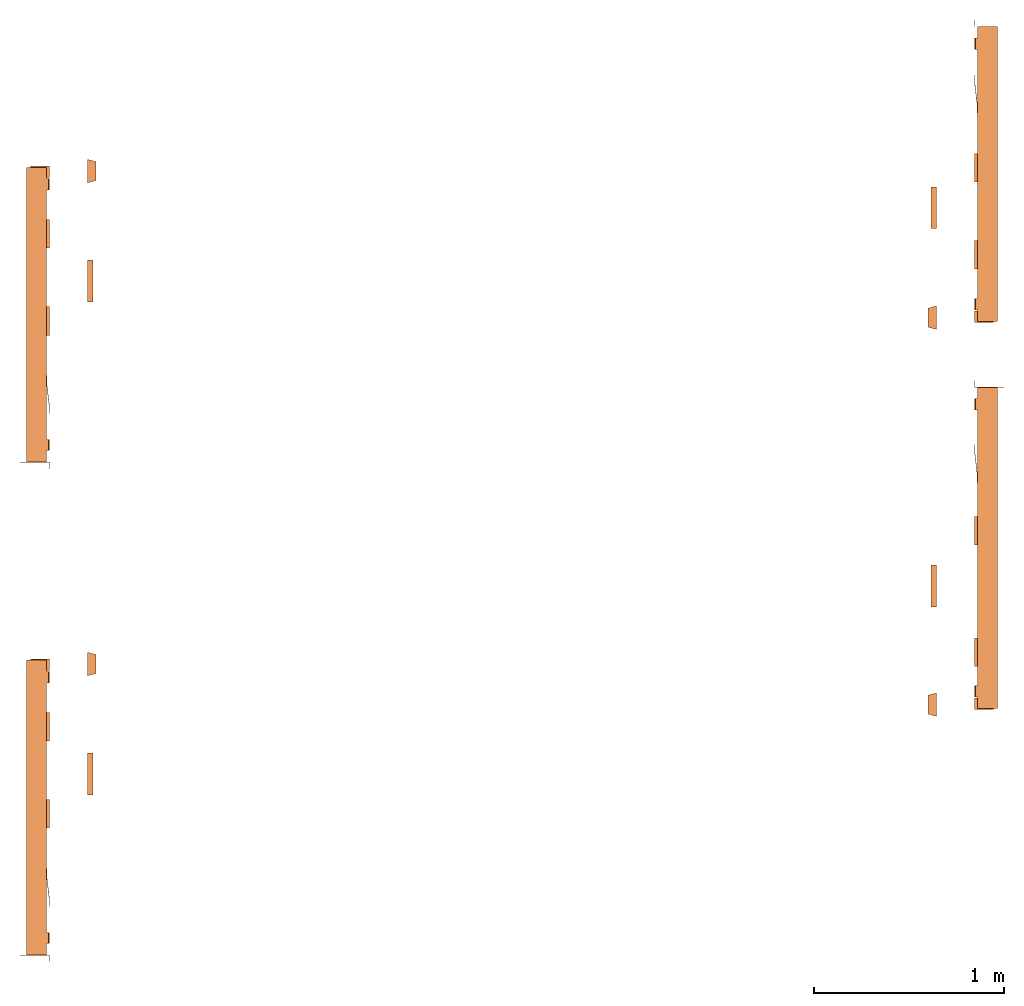
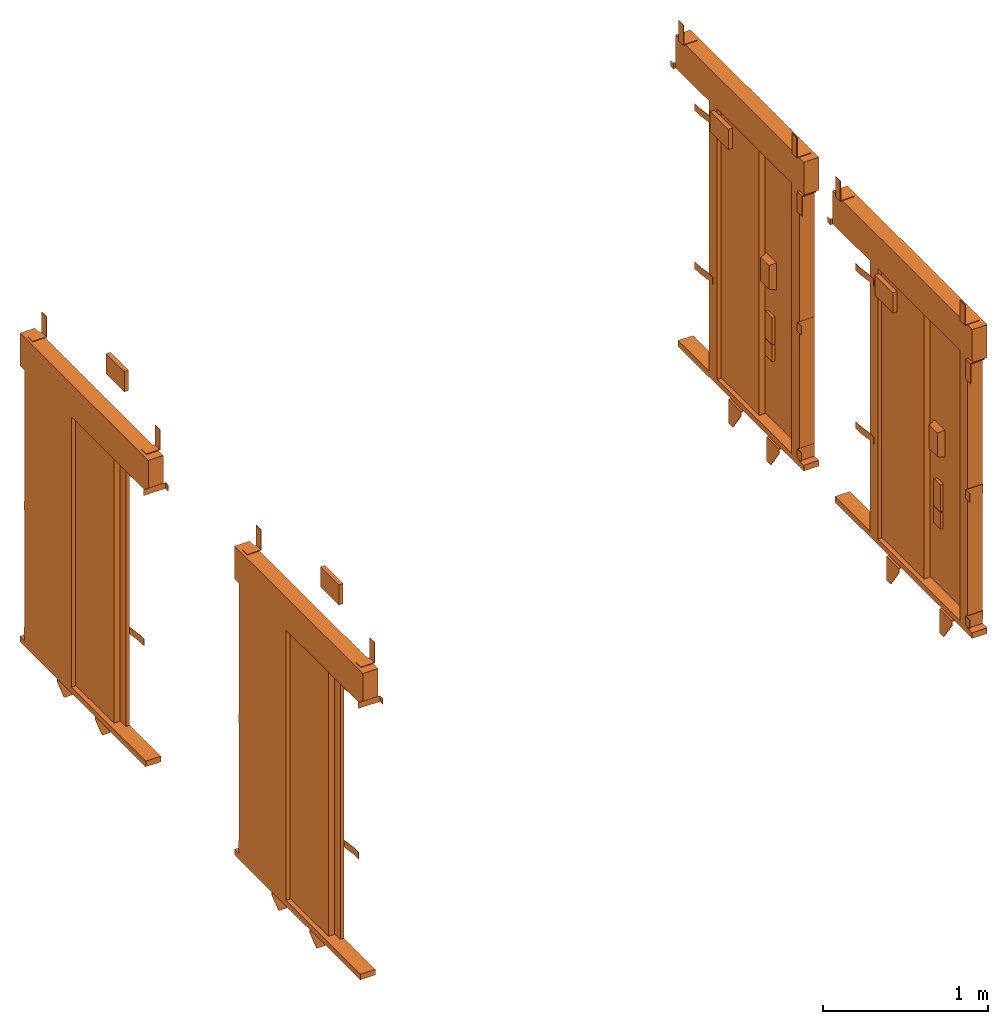
# One storey: 4 proxies.
"""IFC2X3 building model written with IfcOpenShell, lengths in millimetres."""

import ifcopenshell
import ifcopenshell.guid

model = None  # the IFC model being written
_history = None  # IfcOwnerHistory: only IFC2X3 demands one
_inside = {}  # id of a spatial element -> (the spatial element, [elements in it])
_under = {}  # id of a project, library or spatial element -> (it, [spatial elements below it])
_declared = {}  # id of a project -> (the project, [libraries it declares])
_typed = {}  # id of a type object -> (the type object, [elements of that type])
_made_of = {}  # id of a material, layer set ... -> (it, [elements and type objects made of it])


def new_model(schema):
    """Start an empty IFC model of exactly this schema.

    Asked for "IFC4X3", IfcOpenShell would pick the latest addendum, in which some entities
    have other attributes; the version numbers below select the first issue.
    IFC2X3 requires an IfcOwnerHistory on every rooted entity: one is made here for all.
    """
    global model, _history
    if schema == "IFC4X3":
        model = ifcopenshell.file(schema_version=(4, 3, 0, 0))
    else:
        model = ifcopenshell.file(schema=schema)
    _inside.clear()
    _under.clear()
    _declared.clear()
    _typed.clear()
    _made_of.clear()
    _history = None
    if model.schema == "IFC2X3":
        org = make("IfcOrganization", Name="unknown")
        user = make(
            "IfcPersonAndOrganization",
            ThePerson=make("IfcPerson", FamilyName="unknown"),
            TheOrganization=org,
        )
        app = make(
            "IfcApplication",
            ApplicationDeveloper=org,
            Version="unknown",
            ApplicationFullName="unknown",
            ApplicationIdentifier="unknown",
        )
        _history = make(
            "IfcOwnerHistory",
            OwningUser=user,
            OwningApplication=app,
            ChangeAction="ADDED",
            CreationDate=0,
        )
    return model


def make(cls, **values):
    """One entity of the class cls with the attributes given. An attribute that is None is left unset."""
    return model.create_entity(
        cls, **{name: value for name, value in values.items() if value is not None}
    )


def entity(cls, *values):
    """Any entity or typed value of the class cls, its attributes in the order of the schema. None: left unset."""
    e = model.create_entity(cls)
    for i, value in enumerate(values):
        if value is not None:
            e[i] = value
    return e


def rooted(cls, **values):
    """An entity with a GlobalId (a new one), such as an element, a storey or a relation."""
    return make(cls, GlobalId=ifcopenshell.guid.new(), OwnerHistory=_history, **values)


def si_unit(unit_type, name, prefix=None):
    """IfcSIUnit, for example si_unit("LENGTHUNIT", "METRE", prefix="MILLI")."""
    return make("IfcSIUnit", UnitType=unit_type, Prefix=prefix, Name=name)


def converted_unit(unit_type, name, factor, base, dimensions=None, offset=None):
    """IfcConversionBasedUnit, such as the inch: factor (a typed value) times the base unit."""
    return make(
        "IfcConversionBasedUnit"
        if offset is None
        else "IfcConversionBasedUnitWithOffset",
        ConversionOffset=offset,
        Dimensions=None
        if dimensions is None
        else entity("IfcDimensionalExponents", *dimensions),
        UnitType=unit_type,
        Name=name,
        ConversionFactor=make(
            "IfcMeasureWithUnit", ValueComponent=factor, UnitComponent=base
        ),
    )


def derived_unit(unit_type, elements):
    """IfcDerivedUnit: a product of units, each with its exponent."""
    return make(
        "IfcDerivedUnit",
        Elements=[
            make("IfcDerivedUnitElement", Unit=unit, Exponent=power)
            for unit, power in elements
        ],
        UnitType=unit_type,
    )


def assignment(units):
    """IfcUnitAssignment: the units of a project."""
    return None if units is None else make("IfcUnitAssignment", Units=units)


def point(xyz):
    """IfcCartesianPoint."""
    return None if xyz is None else make("IfcCartesianPoint", Coordinates=xyz)


def direction(xyz):
    """IfcDirection."""
    return None if xyz is None else make("IfcDirection", DirectionRatios=xyz)


def frame(location, z_axis=None, x_axis=None):
    """IfcAxis2Placement3D, a coordinate frame: its origin and axes. An axis left out is left unset."""
    return make(
        "IfcAxis2Placement3D",
        Location=point(location),
        Axis=direction(z_axis),
        RefDirection=direction(x_axis),
    )


def origin():
    """The frame at (0, 0, 0) with its axes left unset."""
    return frame((0.0, 0.0, 0.0))


def place(relative_to, where):
    """IfcLocalPlacement: puts the frame where relative to a parent placement (None: the world)."""
    return make(
        "IfcLocalPlacement", PlacementRelTo=relative_to, RelativePlacement=where
    )


def context(
    kind, dimensions, precision=None, world=None, true_north=None, identifier=None
):
    """IfcGeometricRepresentationContext, for example the 3D "Model" context."""
    return make(
        "IfcGeometricRepresentationContext",
        ContextIdentifier=identifier,
        ContextType=kind,
        CoordinateSpaceDimension=dimensions,
        Precision=precision,
        WorldCoordinateSystem=world,
        TrueNorth=true_north,
    )


def subcontext(parent, identifier, kind, view, scale=None):
    """IfcGeometricRepresentationSubContext, for example "Body" below "Model"."""
    return make(
        "IfcGeometricRepresentationSubContext",
        ContextIdentifier=identifier,
        ContextType=kind,
        ParentContext=parent,
        TargetScale=scale,
        TargetView=view,
    )


def project(units=None, contexts=None):
    """IfcProject with its units and contexts."""
    return rooted(
        "IfcProject",
        Name="project",
        RepresentationContexts=contexts,
        UnitsInContext=assignment(units),
    )


def spatial(cls, under=None, at=None, **own):
    """A site, building, storey or space (cls), placed at a placement, below another one or the project."""
    s = rooted(cls, ObjectPlacement=at, **own)
    if under is not None:
        _under.setdefault(under.id(), (under, []))[1].append(s)
    return s


def faces_of(points, faces, orient=None, outer=None):
    """IfcFace entities. A face is a list of loops; a loop is a list of indices into points, from 0.

    orient and outer hold one flag for each loop. By default every Orientation is true, the
    first loop of a face is its IfcFaceOuterBound and the others are IfcFaceBound.
    """
    made = []
    for i, loops in enumerate(faces):
        bounds = []
        for j, loop in enumerate(loops):
            is_outer = j == 0 if outer is None else outer[i][j]
            bounds.append(
                make(
                    "IfcFaceOuterBound" if is_outer else "IfcFaceBound",
                    Bound=make("IfcPolyLoop", Polygon=[points[k] for k in loop]),
                    Orientation=True if orient is None else orient[i][j],
                )
            )
        made.append(make("IfcFace", Bounds=bounds))
    return made


def faceted_brep(points, faces, orient=None, outer=None, voids=None):
    """IfcFacetedBrep: a solid bounded by flat faces; with voids (closed shells), ...WithVoids."""
    shared = [point(p) for p in points]
    hull = make("IfcClosedShell", CfsFaces=faces_of(shared, faces, orient, outer))
    if voids is None:
        return make("IfcFacetedBrep", Outer=hull)
    return make(
        "IfcFacetedBrepWithVoids",
        Outer=hull,
        Voids=[
            make(cls, CfsFaces=faces_of(shared, fs, o, b)) for cls, fs, o, b in voids
        ],
    )


def shape(context_of_items, identifier, shape_type, items):
    """IfcShapeRepresentation: the items that make up one representation, for example the "Body"."""
    return make(
        "IfcShapeRepresentation",
        ContextOfItems=context_of_items,
        RepresentationIdentifier=identifier,
        RepresentationType=shape_type,
        Items=items,
    )


def source(mapping_origin, context_of_items, identifier, shape_type, items):
    """IfcRepresentationMap: a shape defined once, which mapped items show again and again."""
    return make(
        "IfcRepresentationMap",
        MappingOrigin=mapping_origin,
        MappedRepresentation=shape(context_of_items, identifier, shape_type, items),
    )


def transform(
    local_origin,
    x_axis=None,
    y_axis=None,
    z_axis=None,
    scale=None,
    scale2=None,
    scale3=None,
    uniform=True,
):
    """IfcCartesianTransformationOperator3D, or its non-uniform kind. x_axis, y_axis, z_axis: its Axis1, 2, 3."""
    if uniform:
        return make(
            "IfcCartesianTransformationOperator3D",
            Axis1=direction(x_axis),
            Axis2=direction(y_axis),
            LocalOrigin=point(local_origin),
            Scale=scale,
            Axis3=direction(z_axis),
        )
    return make(
        "IfcCartesianTransformationOperator3DnonUniform",
        Axis1=direction(x_axis),
        Axis2=direction(y_axis),
        LocalOrigin=point(local_origin),
        Scale=scale,
        Axis3=direction(z_axis),
        Scale2=scale2,
        Scale3=scale3,
    )


def mapped(mapping_source, mapping_target):
    """IfcMappedItem: shows the shape of a source again, moved by a transform."""
    return make(
        "IfcMappedItem", MappingSource=mapping_source, MappingTarget=mapping_target
    )


def material(Name=None, Category=None):
    """IfcMaterial."""
    return make("IfcMaterial", Name=Name, Category=Category)


def made_of(thing, what):
    """Note that an element or type object is made of a material, layer set ...; save() writes the relation."""
    if what is not None:
        _made_of.setdefault(what.id(), (what, []))[1].append(thing)
    return thing


def type_object(cls, material=None, **own):
    """A type object (cls), such as IfcWallType, which elements share."""
    return made_of(rooted(cls, **own), material)


def type_shapes(of_type, sources):
    """Give a type object the sources (RepresentationMaps) that its elements show as mapped items."""
    of_type.RepresentationMaps = sources


def element(
    cls,
    number,
    at=None,
    inside=None,
    cuts=None,
    type_object=None,
    material=None,
    context=None,
    identifier="Body",
    shape_type=None,
    held_by="IfcProductDefinitionShape",
    body=None,
    shapes=None,
    **own,
):
    """One element of the class cls, such as IfcWall. Its Tag is "e" and its number.

    at: its placement. inside: the storey or other place that contains it. cuts: it is an
    opening in that element (IfcRelVoidsElement). A single representation is given by context,
    identifier, shape_type and body (its items); several are given by shapes. held_by: the class
    of the entity that holds the representations. save() writes the other relations.
    """
    e = rooted(cls, Tag="e%d" % number, ObjectPlacement=at, **own)
    if body is not None:
        shapes = [shape(context, identifier, shape_type, body)]
    if shapes is not None:
        e.Representation = make(held_by, Representations=shapes)
    if inside is not None:
        _inside.setdefault(inside.id(), (inside, []))[1].append(e)
    if cuts is not None:
        rooted(
            "IfcRelVoidsElement", RelatingBuildingElement=cuts, RelatedOpeningElement=e
        )
    if type_object is not None:
        _typed.setdefault(type_object.id(), (type_object, []))[1].append(e)
    return made_of(e, material)


def aggregate(whole, parts):
    """IfcRelAggregates: a whole, such as a stair, and the parts it consists of."""
    return rooted("IfcRelAggregates", RelatingObject=whole, RelatedObjects=parts)


def save(model, path):
    """Write the relations noted so far, then the file.

    IfcRelAggregates (storeys below a building ...), IfcRelContainedInSpatialStructure (elements
    in a storey), IfcRelDefinesByType, IfcRelAssociatesMaterial and IfcRelDeclares: one each for
    every whole, place, type object, material and project.
    """
    for whole, parts in _under.values():
        aggregate(whole, parts)
    for where, things in _inside.values():
        rooted(
            "IfcRelContainedInSpatialStructure",
            RelatedElements=things,
            RelatingStructure=where,
        )
    for kind, things in _typed.values():
        rooted("IfcRelDefinesByType", RelatedObjects=things, RelatingType=kind)
    for what, things in _made_of.values():
        rooted("IfcRelAssociatesMaterial", RelatedObjects=things, RelatingMaterial=what)
    for by, libraries in _declared.values():
        rooted("IfcRelDeclares", RelatingContext=by, RelatedDefinitions=libraries)
    model.write(path)


model = new_model("IFC2X3")

# Units and contexts
model_context = context("Model", 3, precision=0.01, world=origin(), true_north=direction((6.12303176911189e-17, 1.0)))
body_context = subcontext(model_context, "Body", "Model", "MODEL_VIEW")
ifc_project = project(units=[si_unit("LENGTHUNIT", "METRE", prefix="MILLI"), si_unit("AREAUNIT", "SQUARE_METRE"), si_unit("VOLUMEUNIT", "CUBIC_METRE"), converted_unit("PLANEANGLEUNIT", "DEGREE", entity("IfcRatioMeasure", 0.0174532925199433), si_unit("PLANEANGLEUNIT", "RADIAN"), dimensions=[0, 0, 0, 0, 0, 0, 0]), si_unit("MASSUNIT", "GRAM", prefix="KILO"), derived_unit("MASSDENSITYUNIT", [(si_unit("MASSUNIT", "GRAM", prefix="KILO"), 1), (si_unit("LENGTHUNIT", "METRE"), -3)]), derived_unit("MOMENTOFINERTIAUNIT", [(si_unit("LENGTHUNIT", "METRE"), 4)]), si_unit("TIMEUNIT", "SECOND"), si_unit("FREQUENCYUNIT", "HERTZ"), si_unit("THERMODYNAMICTEMPERATUREUNIT", "DEGREE_CELSIUS"), derived_unit("THERMALTRANSMITTANCEUNIT", [(si_unit("MASSUNIT", "GRAM", prefix="KILO"), 1), (si_unit("THERMODYNAMICTEMPERATUREUNIT", "KELVIN"), -1), (si_unit("TIMEUNIT", "SECOND"), -3)]), derived_unit("VOLUMETRICFLOWRATEUNIT", [(si_unit("LENGTHUNIT", "METRE"), 3), (si_unit("TIMEUNIT", "SECOND"), -1)]), derived_unit("MASSFLOWRATEUNIT", [(si_unit("MASSUNIT", "GRAM", prefix="KILO"), 1), (si_unit("TIMEUNIT", "SECOND"), -1)]), derived_unit("ROTATIONALFREQUENCYUNIT", [(si_unit("TIMEUNIT", "SECOND"), -1)]), si_unit("ELECTRICCURRENTUNIT", "AMPERE"), si_unit("ELECTRICVOLTAGEUNIT", "VOLT"), si_unit("POWERUNIT", "WATT"), si_unit("FORCEUNIT", "NEWTON", prefix="KILO"), si_unit("ILLUMINANCEUNIT", "LUX"), si_unit("LUMINOUSFLUXUNIT", "LUMEN"), si_unit("LUMINOUSINTENSITYUNIT", "CANDELA"), derived_unit("USERDEFINED", [(si_unit("MASSUNIT", "GRAM", prefix="KILO"), -1), (si_unit("LENGTHUNIT", "METRE"), -2), (si_unit("TIMEUNIT", "SECOND"), 3), (si_unit("LUMINOUSFLUXUNIT", "LUMEN"), 1)]), derived_unit("LINEARVELOCITYUNIT", [(si_unit("LENGTHUNIT", "METRE"), 1), (si_unit("TIMEUNIT", "SECOND"), -1)]), si_unit("PRESSUREUNIT", "PASCAL"), derived_unit("USERDEFINED", [(si_unit("LENGTHUNIT", "METRE"), -2), (si_unit("MASSUNIT", "GRAM", prefix="KILO"), 1), (si_unit("TIMEUNIT", "SECOND"), -2)]), derived_unit("LINEARFORCEUNIT", [(si_unit("MASSUNIT", "GRAM", prefix="KILO"), 1), (si_unit("LENGTHUNIT", "METRE"), 1), (si_unit("TIMEUNIT", "SECOND"), -2), (si_unit("LENGTHUNIT", "METRE"), -1)]), derived_unit("PLANARFORCEUNIT", [(si_unit("MASSUNIT", "GRAM", prefix="KILO"), 1), (si_unit("LENGTHUNIT", "METRE"), 1), (si_unit("TIMEUNIT", "SECOND"), -2), (si_unit("LENGTHUNIT", "METRE"), -2)])], contexts=[model_context])

# Site, building, storey
site_placement = place(None, origin())
site = spatial("IfcSite", under=ifc_project, at=site_placement, CompositionType="ELEMENT")
building_placement = place(site_placement, origin())
building = spatial("IfcBuilding", under=site, at=building_placement, CompositionType="ELEMENT")
storey_placement = place(building_placement, frame((0.0, 0.0, 4200.0)))
storey = spatial("IfcBuildingStorey", under=building, at=storey_placement, CompositionType="ELEMENT", Elevation=4200.0)

# Proxies
ifc_material = material()
building_element_proxy_type_1 = type_object("IfcBuildingElementProxyType", PredefinedType="NOTDEFINED", material=ifc_material)
shared_shape_1 = source(origin(), body_context, "Body", "Brep", [
    faceted_brep([(-990.0, 1.5, 2038.5), (-990.0, 0.0, 2038.5), (-955.0, 0.0, 2038.5), (-955.0, 155.0, 2038.5), (-956.5, 155.0, 2038.5), (-956.5, 1.5, 2038.5), (-990.0, 1.5, 1995.5), (-956.5, 1.5, 1995.5), (-956.5, 155.0, 1995.5), (-955.0, 155.0, 1995.5), (-955.0, 0.0, 1995.5), (-990.0, 0.0, 1995.5)], [[[0, 1, 2, 3, 4, 5]], [[6, 7, 8, 9, 10, 11]], [[1, 0, 6, 11]], [[2, 1, 11, 10]], [[3, 2, 10, 9]], [[4, 3, 9, 8]], [[5, 4, 8, 7]], [[0, 5, 7, 6]]]),
    faceted_brep([(-699.0, 3.0, 1895.0), (-699.0, 0.0, 1895.0), (-649.0, 0.0, 1895.0), (-549.0, 12.0, 1895.0), (-499.0, 12.0, 1895.0), (-499.0, 15.0, 1895.0), (-549.0, 15.0, 1895.0), (-649.0, 3.0, 1895.0), (-699.0, 3.0, 1845.0), (-649.0, 3.0, 1845.0), (-549.0, 15.0, 1845.0), (-499.0, 15.0, 1845.0), (-499.0, 12.0, 1845.0), (-549.0, 12.0, 1845.0), (-649.0, 0.0, 1845.0), (-699.0, 0.0, 1845.0)], [[[0, 1, 2, 3, 4, 5, 6, 7]], [[8, 9, 10, 11, 12, 13, 14, 15]], [[1, 0, 8, 15]], [[2, 1, 15, 14]], [[3, 2, 14, 13]], [[4, 3, 13, 12]], [[5, 4, 12, 11]], [[6, 5, 11, 10]], [[7, 6, 10, 9]], [[0, 7, 9, 8]]]),
    faceted_brep([(-699.0, 3.0, 725.0), (-699.0, 0.0, 725.0), (-649.0, 0.0, 725.0), (-549.0, 12.0, 725.0), (-499.0, 12.0, 725.0), (-499.0, 15.0, 725.0), (-549.0, 15.0, 725.0), (-649.0, 3.0, 725.0), (-699.0, 3.0, 675.0), (-649.0, 3.0, 675.0), (-549.0, 15.0, 675.0), (-499.0, 15.0, 675.0), (-499.0, 12.0, 675.0), (-549.0, 12.0, 675.0), (-649.0, 0.0, 675.0), (-699.0, 0.0, 675.0)], [[[0, 1, 2, 3, 4, 5, 6, 7]], [[8, 9, 10, 11, 12, 13, 14, 15]], [[1, 0, 8, 15]], [[2, 1, 15, 14]], [[3, 2, 14, 13]], [[4, 3, 13, 12]], [[5, 4, 12, 11]], [[6, 5, 11, 10]], [[7, 6, 10, 9]], [[0, 7, 9, 8]]]),
    faceted_brep([(546.0, 121.0, 95.0), (546.0, 0.0, 95.0), (596.0, 0.0, 95.0), (596.0, 2.0, 95.0), (548.0, 2.0, 95.0), (548.0, 121.0, 95.0), (546.0, 121.0, 31.0), (548.0, 121.0, 31.0), (548.0, 2.0, 31.0), (596.0, 2.0, 31.0), (596.0, 0.0, 31.0), (546.0, 0.0, 31.0)], [[[0, 1, 2, 3, 4, 5]], [[6, 7, 8, 9, 10, 11]], [[1, 0, 6, 11]], [[2, 1, 11, 10]], [[3, 2, 10, 9]], [[4, 3, 9, 8]], [[5, 4, 8, 7]], [[0, 5, 7, 6]]]),
    faceted_brep([(546.0, 121.0, 1032.0), (546.0, 0.0, 1032.0), (596.0, 0.0, 1032.0), (596.0, 2.0, 1032.0), (548.0, 2.0, 1032.0), (548.0, 121.0, 1032.0), (546.0, 121.0, 968.0), (548.0, 121.0, 968.0), (548.0, 2.0, 968.0), (596.0, 2.0, 968.0), (596.0, 0.0, 968.0), (546.0, 0.0, 968.0)], [[[0, 1, 2, 3, 4, 5]], [[6, 7, 8, 9, 10, 11]], [[1, 0, 6, 11]], [[2, 1, 11, 10]], [[3, 2, 10, 9]], [[4, 3, 9, 8]], [[5, 4, 8, 7]], [[0, 5, 7, 6]]]),
    faceted_brep([(221.67, 105.0, -47.0), (324.5, 33.0, -47.0), (324.5, 5.0, -47.0), (179.0, 5.0, -47.0), (179.0, 105.0, -47.0), (221.67, 105.0, -42.0), (174.0, 105.0, -42.0), (174.0, 0.0, -42.0), (324.5, 0.0, -42.0), (324.5, 33.0, -42.0), (179.0, 105.0, -84.0), (174.0, 105.0, -84.0), (174.0, 55.86, -219.0), (174.0, 0.0, -219.0), (324.5, 0.0, -76.19), (324.5, 5.0, -76.19), (224.5, 5.0, -219.0), (179.0, 5.0, -219.0), (224.5, 0.0, -219.0), (179.0, 55.86, -219.0)], [[[0, 1, 2, 3, 4]], [[5, 6, 7, 8, 9]], [[6, 5, 0, 4, 10, 11]], [[6, 11, 12, 13, 7]], [[2, 1, 9, 8, 14, 15]], [[1, 0, 5, 9]], [[15, 16, 17, 3, 2]], [[7, 13, 18, 14, 8]], [[16, 15, 14, 18]], [[18, 13, 12, 19, 17, 16]], [[19, 10, 4, 3, 17]], [[12, 11, 10, 19]]]),
    faceted_brep([(-238.33, 105.0, -47.0), (-135.5, 33.0, -47.0), (-135.5, 5.0, -47.0), (-281.0, 5.0, -47.0), (-281.0, 105.0, -47.0), (-238.33, 105.0, -42.0), (-286.0, 105.0, -42.0), (-286.0, 0.0, -42.0), (-135.5, 0.0, -42.0), (-135.5, 33.0, -42.0), (-281.0, 105.0, -84.0), (-286.0, 105.0, -84.0), (-286.0, 55.86, -219.0), (-286.0, 0.0, -219.0), (-135.5, 0.0, -76.19), (-135.5, 5.0, -76.19), (-235.5, 5.0, -219.0), (-281.0, 5.0, -219.0), (-235.5, 0.0, -219.0), (-281.0, 55.86, -219.0)], [[[0, 1, 2, 3, 4]], [[5, 6, 7, 8, 9]], [[6, 5, 0, 4, 10, 11]], [[6, 11, 12, 13, 7]], [[2, 1, 9, 8, 14, 15]], [[1, 0, 5, 9]], [[15, 16, 17, 3, 2]], [[7, 13, 18, 14, 8]], [[16, 15, 14, 18]], [[18, 13, 12, 19, 17, 16]], [[19, 10, 4, 3, 17]], [[12, 11, 10, 19]]]),
    faceted_brep([(606.0, 100.0, 2000.0), (606.0, 0.0, 2000.0), (606.0, 0.0, 1850.0), (606.0, 4.0, 1850.0), (606.0, 4.0, 1996.0), (606.0, 100.0, 1996.0), (546.0, 100.0, 2000.0), (546.0, 100.0, 1996.0), (546.0, 4.0, 1996.0), (546.0, 4.0, 1850.0), (546.0, 0.0, 1850.0), (546.0, 0.0, 2000.0)], [[[0, 1, 2, 3, 4, 5]], [[6, 7, 8, 9, 10, 11]], [[1, 0, 6, 11]], [[2, 1, 11, 10]], [[3, 2, 10, 9]], [[4, 3, 9, 8]], [[5, 4, 8, 7]], [[0, 5, 7, 6]]]),
    faceted_brep([(540.0, 100.0, 2247.0), (540.0, 4.0, 2247.0), (540.0, 4.0, 2393.0), (540.0, 0.0, 2393.0), (540.0, 0.0, 2243.0), (540.0, 100.0, 2243.0), (480.0, 100.0, 2247.0), (480.0, 100.0, 2243.0), (480.0, 0.0, 2243.0), (480.0, 0.0, 2393.0), (480.0, 4.0, 2393.0), (480.0, 4.0, 2247.0)], [[[0, 1, 2, 3, 4, 5]], [[6, 7, 8, 9, 10, 11]], [[1, 0, 6, 11]], [[2, 1, 11, 10]], [[3, 2, 10, 9]], [[4, 3, 9, 8]], [[5, 4, 8, 7]], [[0, 5, 7, 6]]]),
    faceted_brep([(-835.0, 100.0, 2247.0), (-835.0, 4.0, 2247.0), (-835.0, 4.0, 2393.0), (-835.0, 0.0, 2393.0), (-835.0, 0.0, 2243.0), (-835.0, 100.0, 2243.0), (-895.0, 100.0, 2247.0), (-895.0, 100.0, 2243.0), (-895.0, 0.0, 2243.0), (-895.0, 0.0, 2393.0), (-895.0, 4.0, 2393.0), (-895.0, 4.0, 2247.0)], [[[0, 1, 2, 3, 4, 5]], [[6, 7, 8, 9, 10, 11]], [[1, 0, 6, 11]], [[2, 1, 11, 10]], [[3, 2, 10, 9]], [[4, 3, 9, 8]], [[5, 4, 8, 7]], [[0, 5, 7, 6]]]),
    faceted_brep([(630.0, -246.0, 1587.5), (530.0, -246.0, 1587.5), (530.0, -246.0, 1412.5), (630.0, -246.0, 1412.5), (642.5, -200.0, 1600.0), (642.5, -200.0, 1400.0), (517.5, -200.0, 1400.0), (517.5, -200.0, 1600.0)], [[[0, 1, 2, 3]], [[4, 5, 6, 7]], [[4, 7, 1, 0]], [[7, 6, 2, 1]], [[6, 5, 3, 2]], [[5, 4, 0, 3]]]),
    faceted_brep([(621.5, -220.0, 985.0), (538.5, -220.0, 985.0), (538.5, -220.0, 862.0), (621.5, -220.0, 862.0), (621.5, -200.0, 985.0), (621.5, -200.0, 862.0), (538.5, -200.0, 862.0), (538.5, -200.0, 985.0)], [[[0, 1, 2, 3]], [[4, 5, 6, 7]], [[1, 0, 4, 7]], [[2, 1, 7, 6]], [[3, 2, 6, 5]], [[0, 3, 5, 4]]]),
    faceted_brep([(110.0, -200.0, 2274.5), (110.0, -200.0, 2125.5), (-110.0, -200.0, 2125.5), (-110.0, -200.0, 2274.5), (110.0, -230.0, 2274.5), (-110.0, -230.0, 2274.5), (-110.0, -230.0, 2125.5), (110.0, -230.0, 2125.5)], [[[0, 1, 2, 3]], [[4, 5, 6, 7]], [[5, 4, 0, 3]], [[6, 5, 3, 2]], [[7, 6, 2, 1]], [[4, 7, 1, 0]]]),
    faceted_brep([(594.0, -220.0, 1191.35), (566.0, -220.0, 1191.35), (538.5, -220.0, 1186.14), (538.5, -220.0, 989.0), (621.5, -220.0, 989.0), (621.5, -220.0, 1186.14), (621.5, -200.0, 1186.14), (621.5, -200.0, 989.0), (538.5, -200.0, 989.0), (538.5, -200.0, 1186.14), (566.0, -200.0, 1191.35), (594.0, -200.0, 1191.35)], [[[0, 1, 2, 3, 4, 5]], [[6, 7, 8, 9, 10, 11]], [[3, 2, 9, 8]], [[4, 3, 8, 7]], [[5, 4, 7, 6]], [[6, 11, 0, 5]], [[11, 10, 1, 0]], [[10, 9, 2, 1]]]),
    faceted_brep([(450.0, 87.0, 2000.0), (450.0, 15.0, 2000.0), (546.0, 15.0, 2000.0), (546.0, 120.0, 2000.0), (469.0, 120.0, 2000.0), (469.0, 87.0, 2000.0), (450.0, 87.0, 0.0), (450.0, 15.0, 0.0), (546.0, 15.0, 0.0), (546.0, 120.0, 0.0), (469.0, 120.0, 0.0), (469.0, 87.0, 0.0)], [[[0, 1, 2, 3, 4, 5]], [[1, 0, 6, 7]], [[2, 1, 7, 8]], [[3, 2, 8, 9]], [[4, 3, 9, 10]], [[5, 4, 10, 11]], [[0, 5, 11, 6]], [[6, 11, 10, 9, 8, 7]]]),
    faceted_brep([(-450.0, 41.0, 0.0), (-450.0, 15.0, 0.0), (-546.0, 15.0, 0.0), (-546.0, 41.0, 0.0), (-546.0, 41.0, 2000.0), (-450.0, 41.0, 2000.0), (-546.0, 15.0, 2000.0), (-450.0, 15.0, 2000.0)], [[[0, 1, 2, 3]], [[4, 5, 0, 3]], [[6, 4, 3, 2]], [[7, 6, 2, 1]], [[5, 7, 1, 0]], [[5, 4, 6, 7]]]),
    faceted_brep([(600.0, 15.0, 0.0), (600.0, 15.0, -42.0), (600.0, 120.0, -42.0), (600.0, 120.0, 0.0), (-925.0, 15.0, 0.0), (-925.0, 120.0, 0.0), (-925.0, 120.0, -42.0), (-925.0, 15.0, -42.0)], [[[0, 1, 2, 3]], [[4, 5, 6, 7]], [[1, 0, 4, 7]], [[2, 1, 7, 6]], [[3, 2, 6, 5]], [[0, 3, 5, 4]]]),
    faceted_brep([(600.0, 15.0, 2243.0), (600.0, 15.0, 2000.0), (600.0, 120.0, 2000.0), (600.0, 120.0, 2243.0), (-955.0, 15.0, 2243.0), (-955.0, 120.0, 2243.0), (-955.0, 120.0, 2000.0), (-955.0, 15.0, 2000.0)], [[[0, 1, 2, 3]], [[4, 5, 6, 7]], [[1, 0, 4, 7]], [[2, 1, 7, 6]], [[3, 2, 6, 5]], [[0, 3, 5, 4]]]),
    faceted_brep([(465.0, 120.0, 2000.0), (-22.0, 120.0, 2000.0), (-22.0, 91.0, 2000.0), (465.0, 91.0, 2000.0), (465.0, 120.0, 0.0), (-22.0, 120.0, 0.0), (-22.0, 91.0, 0.0), (465.0, 91.0, 0.0)], [[[0, 1, 2, 3]], [[1, 0, 4, 5]], [[2, 1, 5, 6]], [[3, 2, 6, 7]], [[0, 3, 7, 4]], [[4, 7, 6, 5]]]),
    faceted_brep([(8.0, 87.0, 0.0), (8.0, 45.0, 0.0), (-480.0, 45.0, 0.0), (-480.0, 87.0, 0.0), (-480.0, 87.0, 2000.0), (8.0, 87.0, 2000.0), (-480.0, 45.0, 2000.0), (8.0, 45.0, 2000.0)], [[[0, 1, 2, 3]], [[4, 5, 0, 3]], [[6, 4, 3, 2]], [[7, 6, 2, 1]], [[5, 7, 1, 0]], [[5, 4, 6, 7]]]),
])
type_shapes(building_element_proxy_type_1, [shared_shape_1])
for number, where, z_axis, x_axis in (
    (1, (15840.0, 19312.11, 0.0), (0.0, 0.0, 1.0), (0.0, -1.0, 0.0)),
    (2, (10959.87, 16325.15, 0.0), (0.0, 0.0, 1.0), (0.0, 1.0, 0.0)),
    (3, (10959.87, 18925.15, 0.0), (0.0, 0.0, 1.0), (0.0, 1.0, 0.0)),
):
    element("IfcBuildingElementProxy", number, at=place(storey_placement, frame(where, z_axis=z_axis, x_axis=x_axis)), inside=storey, type_object=building_element_proxy_type_1, material=ifc_material, context=body_context, shape_type="MappedRepresentation", body=[
        mapped(shared_shape_1, transform((0.0, 0.0, 0.0), scale=1.0)),
    ])
building_element_proxy_type_2 = type_object("IfcBuildingElementProxyType", PredefinedType="NOTDEFINED", material=ifc_material)
shared_shape_2 = source(origin(), body_context, "Body", "Brep", [
    faceted_brep([(-1082.35, 1.5, 2038.5), (-1082.35, 0.0, 2038.5), (-1047.35, 0.0, 2038.5), (-1047.35, 155.0, 2038.5), (-1048.85, 155.0, 2038.5), (-1048.85, 1.5, 2038.5), (-1082.35, 1.5, 1995.5), (-1048.85, 1.5, 1995.5), (-1048.85, 155.0, 1995.5), (-1047.35, 155.0, 1995.5), (-1047.35, 0.0, 1995.5), (-1082.35, 0.0, 1995.5)], [[[0, 1, 2, 3, 4, 5]], [[6, 7, 8, 9, 10, 11]], [[1, 0, 6, 11]], [[2, 1, 11, 10]], [[3, 2, 10, 9]], [[4, 3, 9, 8]], [[5, 4, 8, 7]], [[0, 5, 7, 6]]]),
    faceted_brep([(-745.17, 3.0, 1895.0), (-745.17, 0.0, 1895.0), (-695.17, 0.0, 1895.0), (-595.17, 12.0, 1895.0), (-545.17, 12.0, 1895.0), (-545.17, 15.0, 1895.0), (-595.17, 15.0, 1895.0), (-695.17, 3.0, 1895.0), (-745.17, 3.0, 1845.0), (-695.17, 3.0, 1845.0), (-595.17, 15.0, 1845.0), (-545.17, 15.0, 1845.0), (-545.17, 12.0, 1845.0), (-595.17, 12.0, 1845.0), (-695.17, 0.0, 1845.0), (-745.17, 0.0, 1845.0)], [[[0, 1, 2, 3, 4, 5, 6, 7]], [[8, 9, 10, 11, 12, 13, 14, 15]], [[1, 0, 8, 15]], [[2, 1, 15, 14]], [[3, 2, 14, 13]], [[4, 3, 13, 12]], [[5, 4, 12, 11]], [[6, 5, 11, 10]], [[7, 6, 10, 9]], [[0, 7, 9, 8]]]),
    faceted_brep([(-745.17, 3.0, 725.0), (-745.17, 0.0, 725.0), (-695.17, 0.0, 725.0), (-595.17, 12.0, 725.0), (-545.17, 12.0, 725.0), (-545.17, 15.0, 725.0), (-595.17, 15.0, 725.0), (-695.17, 3.0, 725.0), (-745.17, 3.0, 675.0), (-695.17, 3.0, 675.0), (-595.17, 15.0, 675.0), (-545.17, 15.0, 675.0), (-545.17, 12.0, 675.0), (-595.17, 12.0, 675.0), (-695.17, 0.0, 675.0), (-745.17, 0.0, 675.0)], [[[0, 1, 2, 3, 4, 5, 6, 7]], [[8, 9, 10, 11, 12, 13, 14, 15]], [[1, 0, 8, 15]], [[2, 1, 15, 14]], [[3, 2, 14, 13]], [[4, 3, 13, 12]], [[5, 4, 12, 11]], [[6, 5, 11, 10]], [[7, 6, 10, 9]], [[0, 7, 9, 8]]]),
    faceted_brep([(592.17, 121.0, 95.0), (592.17, 0.0, 95.0), (642.17, 0.0, 95.0), (642.17, 2.0, 95.0), (594.17, 2.0, 95.0), (594.17, 121.0, 95.0), (592.17, 121.0, 31.0), (594.17, 121.0, 31.0), (594.17, 2.0, 31.0), (642.17, 2.0, 31.0), (642.17, 0.0, 31.0), (592.17, 0.0, 31.0)], [[[0, 1, 2, 3, 4, 5]], [[6, 7, 8, 9, 10, 11]], [[1, 0, 6, 11]], [[2, 1, 11, 10]], [[3, 2, 10, 9]], [[4, 3, 9, 8]], [[5, 4, 8, 7]], [[0, 5, 7, 6]]]),
    faceted_brep([(592.17, 121.0, 1032.0), (592.17, 0.0, 1032.0), (642.17, 0.0, 1032.0), (642.17, 2.0, 1032.0), (594.17, 2.0, 1032.0), (594.17, 121.0, 1032.0), (592.17, 121.0, 968.0), (594.17, 121.0, 968.0), (594.17, 2.0, 968.0), (642.17, 2.0, 968.0), (642.17, 0.0, 968.0), (592.17, 0.0, 968.0)], [[[0, 1, 2, 3, 4, 5]], [[6, 7, 8, 9, 10, 11]], [[1, 0, 6, 11]], [[2, 1, 11, 10]], [[3, 2, 10, 9]], [[4, 3, 9, 8]], [[5, 4, 8, 7]], [[0, 5, 7, 6]]]),
    faceted_brep([(322.85, 105.0, -47.0), (425.67, 33.0, -47.0), (425.67, 5.0, -47.0), (280.17, 5.0, -47.0), (280.17, 105.0, -47.0), (322.85, 105.0, -42.0), (275.17, 105.0, -42.0), (275.17, 0.0, -42.0), (425.67, 0.0, -42.0), (425.67, 33.0, -42.0), (280.17, 105.0, -84.0), (275.17, 105.0, -84.0), (275.17, 55.86, -219.0), (275.17, 0.0, -219.0), (425.67, 0.0, -76.19), (425.67, 5.0, -76.19), (325.67, 5.0, -219.0), (280.17, 5.0, -219.0), (325.67, 0.0, -219.0), (280.17, 55.86, -219.0)], [[[0, 1, 2, 3, 4]], [[5, 6, 7, 8, 9]], [[6, 5, 0, 4, 10, 11]], [[6, 11, 12, 13, 7]], [[2, 1, 9, 8, 14, 15]], [[1, 0, 5, 9]], [[15, 16, 17, 3, 2]], [[7, 13, 18, 14, 8]], [[16, 15, 14, 18]], [[18, 13, 12, 19, 17, 16]], [[19, 10, 4, 3, 17]], [[12, 11, 10, 19]]]),
    faceted_brep([(-319.5, 105.0, -47.0), (-216.67, 33.0, -47.0), (-216.67, 5.0, -47.0), (-362.17, 5.0, -47.0), (-362.17, 105.0, -47.0), (-319.5, 105.0, -42.0), (-367.17, 105.0, -42.0), (-367.17, 0.0, -42.0), (-216.67, 0.0, -42.0), (-216.67, 33.0, -42.0), (-362.17, 105.0, -84.0), (-367.17, 105.0, -84.0), (-367.17, 55.86, -219.0), (-367.17, 0.0, -219.0), (-216.67, 0.0, -76.19), (-216.67, 5.0, -76.19), (-316.67, 5.0, -219.0), (-362.17, 5.0, -219.0), (-316.67, 0.0, -219.0), (-362.17, 55.86, -219.0)], [[[0, 1, 2, 3, 4]], [[5, 6, 7, 8, 9]], [[6, 5, 0, 4, 10, 11]], [[6, 11, 12, 13, 7]], [[2, 1, 9, 8, 14, 15]], [[1, 0, 5, 9]], [[15, 16, 17, 3, 2]], [[7, 13, 18, 14, 8]], [[16, 15, 14, 18]], [[18, 13, 12, 19, 17, 16]], [[19, 10, 4, 3, 17]], [[12, 11, 10, 19]]]),
    faceted_brep([(652.17, 100.0, 2000.0), (652.17, 0.0, 2000.0), (652.17, 0.0, 1850.0), (652.17, 4.0, 1850.0), (652.17, 4.0, 1996.0), (652.17, 100.0, 1996.0), (592.17, 100.0, 2000.0), (592.17, 100.0, 1996.0), (592.17, 4.0, 1996.0), (592.17, 4.0, 1850.0), (592.17, 0.0, 1850.0), (592.17, 0.0, 2000.0)], [[[0, 1, 2, 3, 4, 5]], [[6, 7, 8, 9, 10, 11]], [[1, 0, 6, 11]], [[2, 1, 11, 10]], [[3, 2, 10, 9]], [[4, 3, 9, 8]], [[5, 4, 8, 7]], [[0, 5, 7, 6]]]),
    faceted_brep([(586.17, 100.0, 2247.0), (586.17, 4.0, 2247.0), (586.17, 4.0, 2393.0), (586.17, 0.0, 2393.0), (586.17, 0.0, 2243.0), (586.17, 100.0, 2243.0), (526.17, 100.0, 2247.0), (526.17, 100.0, 2243.0), (526.17, 0.0, 2243.0), (526.17, 0.0, 2393.0), (526.17, 4.0, 2393.0), (526.17, 4.0, 2247.0)], [[[0, 1, 2, 3, 4, 5]], [[6, 7, 8, 9, 10, 11]], [[1, 0, 6, 11]], [[2, 1, 11, 10]], [[3, 2, 10, 9]], [[4, 3, 9, 8]], [[5, 4, 8, 7]], [[0, 5, 7, 6]]]),
    faceted_brep([(-927.35, 100.0, 2247.0), (-927.35, 4.0, 2247.0), (-927.35, 4.0, 2393.0), (-927.35, 0.0, 2393.0), (-927.35, 0.0, 2243.0), (-927.35, 100.0, 2243.0), (-987.35, 100.0, 2247.0), (-987.35, 100.0, 2243.0), (-987.35, 0.0, 2243.0), (-987.35, 0.0, 2393.0), (-987.35, 4.0, 2393.0), (-987.35, 4.0, 2247.0)], [[[0, 1, 2, 3, 4, 5]], [[6, 7, 8, 9, 10, 11]], [[1, 0, 6, 11]], [[2, 1, 11, 10]], [[3, 2, 10, 9]], [[4, 3, 9, 8]], [[5, 4, 8, 7]], [[0, 5, 7, 6]]]),
    faceted_brep([(676.17, -246.0, 1587.5), (576.17, -246.0, 1587.5), (576.17, -246.0, 1412.5), (676.17, -246.0, 1412.5), (688.67, -200.0, 1600.0), (688.67, -200.0, 1400.0), (563.67, -200.0, 1400.0), (563.67, -200.0, 1600.0)], [[[0, 1, 2, 3]], [[4, 5, 6, 7]], [[4, 7, 1, 0]], [[7, 6, 2, 1]], [[6, 5, 3, 2]], [[5, 4, 0, 3]]]),
    faceted_brep([(667.67, -220.0, 985.0), (584.67, -220.0, 985.0), (584.67, -220.0, 862.0), (667.67, -220.0, 862.0), (667.67, -200.0, 985.0), (667.67, -200.0, 862.0), (584.67, -200.0, 862.0), (584.67, -200.0, 985.0)], [[[0, 1, 2, 3]], [[4, 5, 6, 7]], [[1, 0, 4, 7]], [[2, 1, 7, 6]], [[3, 2, 6, 5]], [[0, 3, 5, 4]]]),
    faceted_brep([(110.0, -200.0, 2274.5), (110.0, -200.0, 2125.5), (-110.0, -200.0, 2125.5), (-110.0, -200.0, 2274.5), (110.0, -230.0, 2274.5), (-110.0, -230.0, 2274.5), (-110.0, -230.0, 2125.5), (110.0, -230.0, 2125.5)], [[[0, 1, 2, 3]], [[4, 5, 6, 7]], [[5, 4, 0, 3]], [[6, 5, 3, 2]], [[7, 6, 2, 1]], [[4, 7, 1, 0]]]),
    faceted_brep([(640.17, -220.0, 1191.35), (612.18, -220.0, 1191.35), (584.67, -220.0, 1186.14), (584.67, -220.0, 989.0), (667.67, -220.0, 989.0), (667.67, -220.0, 1186.14), (667.67, -200.0, 1186.14), (667.67, -200.0, 989.0), (584.67, -200.0, 989.0), (584.67, -200.0, 1186.14), (612.18, -200.0, 1191.35), (640.17, -200.0, 1191.35)], [[[0, 1, 2, 3, 4, 5]], [[6, 7, 8, 9, 10, 11]], [[3, 2, 9, 8]], [[4, 3, 8, 7]], [[5, 4, 7, 6]], [[6, 11, 0, 5]], [[11, 10, 1, 0]], [[10, 9, 2, 1]]]),
    faceted_brep([(496.17, 87.0, 2000.0), (496.17, 15.0, 2000.0), (592.17, 15.0, 2000.0), (592.17, 120.0, 2000.0), (515.17, 120.0, 2000.0), (515.17, 87.0, 2000.0), (496.17, 87.0, 0.0), (496.17, 15.0, 0.0), (592.17, 15.0, 0.0), (592.17, 120.0, 0.0), (515.17, 120.0, 0.0), (515.17, 87.0, 0.0)], [[[0, 1, 2, 3, 4, 5]], [[1, 0, 6, 7]], [[2, 1, 7, 8]], [[3, 2, 8, 9]], [[4, 3, 9, 10]], [[5, 4, 10, 11]], [[0, 5, 11, 6]], [[6, 11, 10, 9, 8, 7]]]),
    faceted_brep([(-496.17, 41.0, 0.0), (-496.17, 15.0, 0.0), (-592.17, 15.0, 0.0), (-592.17, 41.0, 0.0), (-592.17, 41.0, 2000.0), (-496.17, 41.0, 2000.0), (-592.17, 15.0, 2000.0), (-496.17, 15.0, 2000.0)], [[[0, 1, 2, 3]], [[4, 5, 0, 3]], [[6, 4, 3, 2]], [[7, 6, 2, 1]], [[5, 7, 1, 0]], [[5, 4, 6, 7]]]),
    faceted_brep([(646.17, 15.0, 0.0), (646.17, 15.0, -42.0), (646.17, 120.0, -42.0), (646.17, 120.0, 0.0), (-1017.35, 15.0, 0.0), (-1017.35, 120.0, 0.0), (-1017.35, 120.0, -42.0), (-1017.35, 15.0, -42.0)], [[[0, 1, 2, 3]], [[4, 5, 6, 7]], [[1, 0, 4, 7]], [[2, 1, 7, 6]], [[3, 2, 6, 5]], [[0, 3, 5, 4]]]),
    faceted_brep([(646.17, 15.0, 2243.0), (646.17, 15.0, 2000.0), (646.17, 120.0, 2000.0), (646.17, 120.0, 2243.0), (-1047.35, 15.0, 2243.0), (-1047.35, 120.0, 2243.0), (-1047.35, 120.0, 2000.0), (-1047.35, 15.0, 2000.0)], [[[0, 1, 2, 3]], [[4, 5, 6, 7]], [[1, 0, 4, 7]], [[2, 1, 7, 6]], [[3, 2, 6, 5]], [[0, 3, 5, 4]]]),
    faceted_brep([(511.17, 120.0, 2000.0), (-22.0, 120.0, 2000.0), (-22.0, 91.0, 2000.0), (511.17, 91.0, 2000.0), (511.17, 120.0, 0.0), (-22.0, 120.0, 0.0), (-22.0, 91.0, 0.0), (511.17, 91.0, 0.0)], [[[0, 1, 2, 3]], [[1, 0, 4, 5]], [[2, 1, 5, 6]], [[3, 2, 6, 7]], [[0, 3, 7, 4]], [[4, 7, 6, 5]]]),
    faceted_brep([(8.0, 87.0, 0.0), (8.0, 45.0, 0.0), (-526.17, 45.0, 0.0), (-526.17, 87.0, 0.0), (-526.17, 87.0, 2000.0), (8.0, 87.0, 2000.0), (-526.17, 45.0, 2000.0), (8.0, 45.0, 2000.0)], [[[0, 1, 2, 3]], [[4, 5, 0, 3]], [[6, 4, 3, 2]], [[7, 6, 2, 1]], [[5, 7, 1, 0]], [[5, 4, 6, 7]]]),
])
type_shapes(building_element_proxy_type_2, [shared_shape_2])
proxy_placement = place(storey_placement, frame((15840.0, 17317.26, 0.0), z_axis=(0.0, 0.0, 1.0), x_axis=(0.0, -1.0, 0.0)))
element("IfcBuildingElementProxy", 4, at=proxy_placement, inside=storey, type_object=building_element_proxy_type_2, material=ifc_material, context=body_context, shape_type="MappedRepresentation", body=[
    mapped(shared_shape_2, transform((0.0, 0.0, 0.0), scale=1.0)),
])

save(model, "model.ifc")
